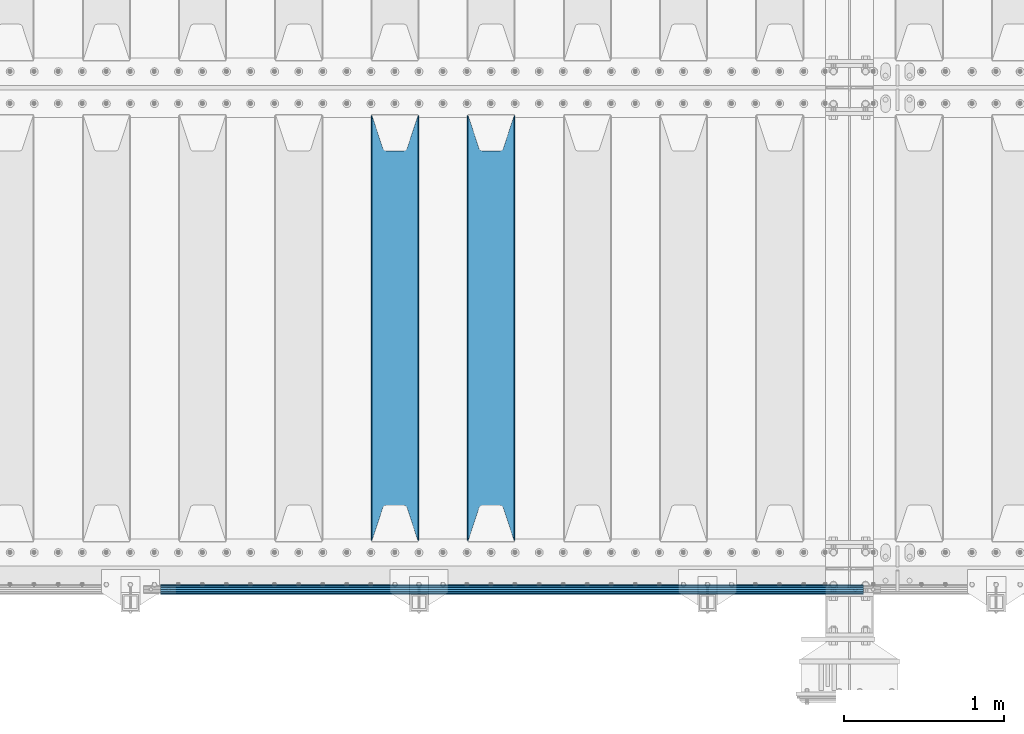
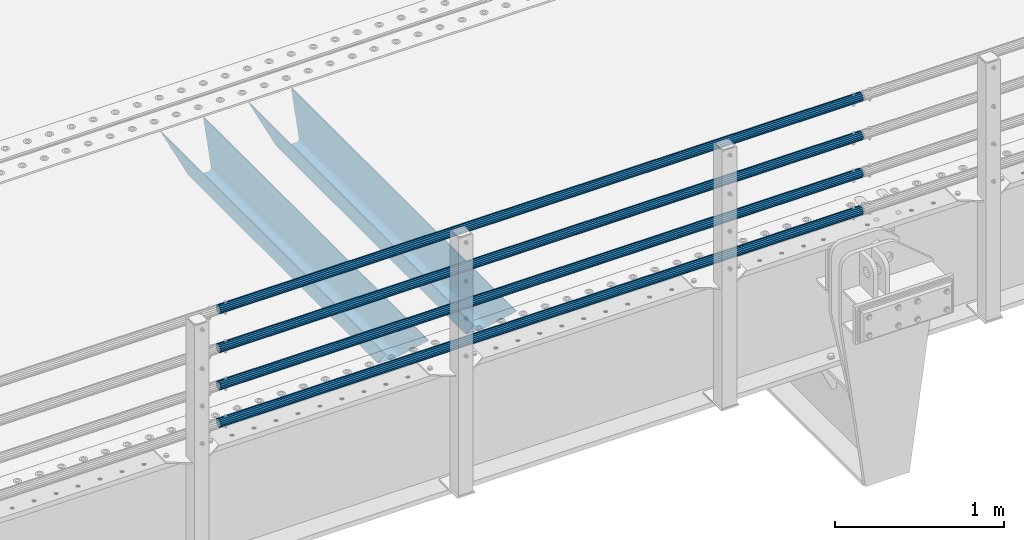
# One storey, part 120 of 242: 6 beams.
"""IFC2X3 building model written with IfcOpenShell, lengths in millimetres."""

from ifc_helpers import new_model, si_unit, frame, origin_with_axes, place, context, subcontext, project, spatial, faceted_brep, material, type_object, element, save


model = new_model("IFC2X3")

# Units and contexts
model_context = context("Model", 3, precision=1e-05, world=origin_with_axes())
body_context = subcontext(model_context, "Body", "Model", "MODEL_VIEW")
ifc_project = project(units=[si_unit("LENGTHUNIT", "METRE", prefix="MILLI"), si_unit("AREAUNIT", "SQUARE_METRE"), si_unit("VOLUMEUNIT", "CUBIC_METRE"), si_unit("MASSUNIT", "GRAM", prefix="KILO"), si_unit("TIMEUNIT", "SECOND"), si_unit("PLANEANGLEUNIT", "RADIAN"), si_unit("SOLIDANGLEUNIT", "STERADIAN"), si_unit("THERMODYNAMICTEMPERATUREUNIT", "DEGREE_CELSIUS"), si_unit("LUMINOUSINTENSITYUNIT", "LUMEN")], contexts=[model_context])

# Site, building, storey
site_placement = place(None, origin_with_axes())
site = spatial("IfcSite", under=ifc_project, at=site_placement, CompositionType="ELEMENT")
building_placement = place(site_placement, origin_with_axes())
building = spatial("IfcBuilding", under=site, at=building_placement, Name="Standard", CompositionType="ELEMENT")
storey_placement = place(building_placement, origin_with_axes())
storey = spatial("IfcBuildingStorey", under=building, at=storey_placement, Name="Undefined", CompositionType="ELEMENT", Elevation=0.0)

# Beams
ifc_material_1 = material()
beam_type_1 = type_object("IfcBeamType", PredefinedType="NOTDEFINED")
beam_1_placement = place(storey_placement, frame((-28328.0000000001, -24129.8499999998, 149.849999999726), z_axis=(0.0, 0.0, -1.0), x_axis=(-1.0, 0.0, 0.0)))
element("IfcBeam", 1, at=beam_1_placement, inside=storey, type_object=beam_type_1, material=ifc_material_1, context=body_context, shape_type="Brep", body=[
    faceted_brep([(0.0, -26.5499999999993, 0.0), (0.0, -24.5290015881765, 10.1602451292931), (4384.0, -24.5290015881765, 10.1602451292931), (4384.0, -26.5499999999993, 0.0), (0.0, -18.7736850405017, 18.7736850405028), (4384.0, -18.7736850405017, 18.7736850405028), (0.0, -10.1602451292929, 24.5290015881747), (4384.0, -10.1602451292929, 24.5290015881747), (0.0, 0.0, 26.55), (4384.0, 0.0, 26.55), (0.0, 10.1602451292929, 24.5290015881747), (4384.0, 10.1602451292929, 24.5290015881747), (0.0, 18.7736850405017, 18.7736850405028), (4384.0, 18.7736850405017, 18.7736850405028), (0.0, 24.5290015881765, 10.1602451292931), (4384.0, 24.5290015881765, 10.1602451292931), (0.0, 26.5499999999993, 0.0), (4384.0, 26.5499999999993, 0.0), (0.0, 24.5290015881765, -10.1602451292931), (4384.0, 24.5290015881765, -10.1602451292931), (0.0, 18.7736850405017, -18.7736850405028), (4384.0, 18.7736850405017, -18.7736850405028), (0.0, 10.1602451292929, -24.5290015881747), (4384.0, 10.1602451292929, -24.5290015881747), (0.0, 0.0, -26.55), (4384.0, 0.0, -26.55), (0.0, -10.1602451292929, -24.5290015881747), (4384.0, -10.1602451292929, -24.5290015881747), (0.0, -18.7736850405017, -18.7736850405028), (4384.0, -18.7736850405017, -18.7736850405028), (0.0, -24.5290015881765, -10.1602451292931), (4384.0, -24.5290015881765, -10.1602451292931), (0.0, -30.1500000000015, 0.0), (0.0, -27.8549679052157, -11.5379054858058), (4384.0, -27.8549679052157, -11.5379054858075), (4384.0, -30.1500000000015, 0.0), (0.0, -21.3192694527752, -21.3192694527752), (4384.0, -21.3192694527752, -21.3192694527744), (0.0, -11.5379054858058, -27.8549679052157), (4384.0, -11.5379054858058, -27.8549679052153), (0.0, 0.0, -30.1500000000015), (4384.0, 0.0, -30.15), (0.0, 11.5379054858058, -27.8549679052157), (4384.0, 11.5379054858058, -27.8549679052153), (0.0, 21.3192694527752, -21.3192694527752), (4384.0, 21.3192694527752, -21.3192694527744), (0.0, 27.8549679052157, -11.5379054858058), (4384.0, 27.8549679052157, -11.5379054858074), (0.0, 30.1500000000015, 0.0), (4384.0, 30.1500000000015, 0.0), (0.0, 27.8549679052157, 11.5379054858058), (4384.0, 27.8549679052157, 11.5379054858075), (0.0, 21.3192694527752, 21.3192694527752), (4384.0, 21.3192694527752, 21.3192694527744), (0.0, 11.5379054858058, 27.8549679052157), (4384.0, 11.5379054858058, 27.8549679052153), (0.0, 0.0, 30.1500000000015), (4384.0, 0.0, 30.15), (0.0, -11.5379054858058, 27.8549679052157), (4384.0, -11.5379054858058, 27.8549679052153), (0.0, -21.3192694527752, 21.3192694527752), (4384.0, -21.3192694527752, 21.3192694527744), (0.0, -27.8549679052157, 11.5379054858058), (4384.0, -27.8549679052157, 11.5379054858075)], [[[0, 1, 2, 3]], [[1, 4, 5, 2]], [[4, 6, 7, 5]], [[6, 8, 9, 7]], [[8, 10, 11, 9]], [[10, 12, 13, 11]], [[12, 14, 15, 13]], [[14, 16, 17, 15]], [[16, 18, 19, 17]], [[18, 20, 21, 19]], [[20, 22, 23, 21]], [[22, 24, 25, 23]], [[24, 26, 27, 25]], [[26, 28, 29, 27]], [[28, 30, 31, 29]], [[30, 0, 3, 31]], [[32, 33, 34, 35]], [[33, 36, 37, 34]], [[36, 38, 39, 37]], [[38, 40, 41, 39]], [[40, 42, 43, 41]], [[42, 44, 45, 43]], [[44, 46, 47, 45]], [[46, 48, 49, 47]], [[48, 50, 51, 49]], [[50, 52, 53, 51]], [[52, 54, 55, 53]], [[54, 56, 57, 55]], [[56, 58, 59, 57]], [[58, 60, 61, 59]], [[60, 62, 63, 61]], [[62, 32, 35, 63]], [[37, 39, 41, 43, 45, 47, 49, 51, 53, 55, 57, 59, 61, 63, 35, 34], [5, 7, 9, 11, 13, 15, 17, 19, 21, 23, 25, 27, 29, 31, 3, 2]], [[62, 60, 58, 56, 54, 52, 50, 48, 46, 44, 42, 40, 38, 36, 33, 32], [30, 28, 26, 24, 22, 20, 18, 16, 14, 12, 10, 8, 6, 4, 1, 0]]]),
])
beam_2_placement = place(storey_placement, frame((-28328.0000000001, -24129.8499999998, 420.149999999729), z_axis=(0.0, 0.0, -1.0), x_axis=(-1.0, 0.0, 0.0)))
element("IfcBeam", 2, at=beam_2_placement, inside=storey, type_object=beam_type_1, material=ifc_material_1, context=body_context, shape_type="Brep", body=[
    faceted_brep([(0.0, -26.5499999999993, 0.0), (0.0, -24.5290015881765, 10.1602451292931), (4384.0, -24.5290015881765, 10.1602451292931), (4384.0, -26.5499999999993, 0.0), (0.0, -18.7736850405017, 18.7736850405028), (4384.0, -18.7736850405017, 18.7736850405028), (0.0, -10.1602451292929, 24.5290015881747), (4384.0, -10.1602451292929, 24.5290015881747), (0.0, 0.0, 26.55), (4384.0, 0.0, 26.55), (0.0, 10.1602451292929, 24.5290015881747), (4384.0, 10.1602451292929, 24.5290015881747), (0.0, 18.7736850405017, 18.7736850405028), (4384.0, 18.7736850405017, 18.7736850405028), (0.0, 24.5290015881765, 10.1602451292931), (4384.0, 24.5290015881765, 10.1602451292931), (0.0, 26.5499999999993, 0.0), (4384.0, 26.5499999999993, 0.0), (0.0, 24.5290015881765, -10.1602451292931), (4384.0, 24.5290015881765, -10.1602451292931), (0.0, 18.7736850405017, -18.7736850405028), (4384.0, 18.7736850405017, -18.7736850405028), (0.0, 10.1602451292929, -24.5290015881747), (4384.0, 10.1602451292929, -24.5290015881747), (0.0, 0.0, -26.55), (4384.0, 0.0, -26.55), (0.0, -10.1602451292929, -24.5290015881747), (4384.0, -10.1602451292929, -24.5290015881747), (0.0, -18.7736850405017, -18.7736850405028), (4384.0, -18.7736850405017, -18.7736850405028), (0.0, -24.5290015881765, -10.1602451292931), (4384.0, -24.5290015881765, -10.1602451292931), (0.0, -30.1500000000015, 0.0), (0.0, -27.8549679052157, -11.5379054858058), (4384.0, -27.8549679052157, -11.5379054858075), (4384.0, -30.1500000000015, 0.0), (0.0, -21.3192694527752, -21.3192694527752), (4384.0, -21.3192694527752, -21.3192694527744), (0.0, -11.5379054858058, -27.8549679052157), (4384.0, -11.5379054858058, -27.8549679052153), (0.0, 0.0, -30.1500000000015), (4384.0, 0.0, -30.15), (0.0, 11.5379054858058, -27.8549679052157), (4384.0, 11.5379054858058, -27.8549679052153), (0.0, 21.3192694527752, -21.3192694527752), (4384.0, 21.3192694527752, -21.3192694527744), (0.0, 27.8549679052157, -11.5379054858058), (4384.0, 27.8549679052157, -11.5379054858074), (0.0, 30.1500000000015, 0.0), (4384.0, 30.1500000000015, 0.0), (0.0, 27.8549679052157, 11.5379054858058), (4384.0, 27.8549679052157, 11.5379054858075), (0.0, 21.3192694527752, 21.3192694527752), (4384.0, 21.3192694527752, 21.3192694527744), (0.0, 11.5379054858058, 27.8549679052157), (4384.0, 11.5379054858058, 27.8549679052153), (0.0, 0.0, 30.1500000000015), (4384.0, 0.0, 30.15), (0.0, -11.5379054858058, 27.8549679052157), (4384.0, -11.5379054858058, 27.8549679052153), (0.0, -21.3192694527752, 21.3192694527752), (4384.0, -21.3192694527752, 21.3192694527744), (0.0, -27.8549679052157, 11.5379054858058), (4384.0, -27.8549679052157, 11.5379054858075)], [[[0, 1, 2, 3]], [[1, 4, 5, 2]], [[4, 6, 7, 5]], [[6, 8, 9, 7]], [[8, 10, 11, 9]], [[10, 12, 13, 11]], [[12, 14, 15, 13]], [[14, 16, 17, 15]], [[16, 18, 19, 17]], [[18, 20, 21, 19]], [[20, 22, 23, 21]], [[22, 24, 25, 23]], [[24, 26, 27, 25]], [[26, 28, 29, 27]], [[28, 30, 31, 29]], [[30, 0, 3, 31]], [[32, 33, 34, 35]], [[33, 36, 37, 34]], [[36, 38, 39, 37]], [[38, 40, 41, 39]], [[40, 42, 43, 41]], [[42, 44, 45, 43]], [[44, 46, 47, 45]], [[46, 48, 49, 47]], [[48, 50, 51, 49]], [[50, 52, 53, 51]], [[52, 54, 55, 53]], [[54, 56, 57, 55]], [[56, 58, 59, 57]], [[58, 60, 61, 59]], [[60, 62, 63, 61]], [[62, 32, 35, 63]], [[37, 39, 41, 43, 45, 47, 49, 51, 53, 55, 57, 59, 61, 63, 35, 34], [5, 7, 9, 11, 13, 15, 17, 19, 21, 23, 25, 27, 29, 31, 3, 2]], [[62, 60, 58, 56, 54, 52, 50, 48, 46, 44, 42, 40, 38, 36, 33, 32], [30, 28, 26, 24, 22, 20, 18, 16, 14, 12, 10, 8, 6, 4, 1, 0]]]),
])
beam_3_placement = place(storey_placement, frame((-28328.0000000001, -24129.8499999998, 969.849999999726), z_axis=(0.0, 0.0, -1.0), x_axis=(-1.0, 0.0, 0.0)))
element("IfcBeam", 3, at=beam_3_placement, inside=storey, type_object=beam_type_1, material=ifc_material_1, context=body_context, shape_type="Brep", body=[
    faceted_brep([(0.0, -26.5499999999993, 0.0), (0.0, -24.5290015881765, 10.1602451292931), (4384.0, -24.5290015881765, 10.1602451292931), (4384.0, -26.5499999999993, 0.0), (0.0, -18.7736850405017, 18.7736850405028), (4384.0, -18.7736850405017, 18.7736850405028), (0.0, -10.1602451292929, 24.5290015881747), (4384.0, -10.1602451292929, 24.5290015881747), (0.0, 0.0, 26.55), (4384.0, 0.0, 26.55), (0.0, 10.1602451292929, 24.5290015881747), (4384.0, 10.1602451292929, 24.5290015881747), (0.0, 18.7736850405017, 18.7736850405028), (4384.0, 18.7736850405017, 18.7736850405028), (0.0, 24.5290015881765, 10.1602451292931), (4384.0, 24.5290015881765, 10.1602451292931), (0.0, 26.5499999999993, 0.0), (4384.0, 26.5499999999993, 0.0), (0.0, 24.5290015881765, -10.1602451292931), (4384.0, 24.5290015881765, -10.1602451292931), (0.0, 18.7736850405017, -18.7736850405028), (4384.0, 18.7736850405017, -18.7736850405028), (0.0, 10.1602451292929, -24.5290015881747), (4384.0, 10.1602451292929, -24.5290015881747), (0.0, 0.0, -26.55), (4384.0, 0.0, -26.55), (0.0, -10.1602451292929, -24.5290015881747), (4384.0, -10.1602451292929, -24.5290015881747), (0.0, -18.7736850405017, -18.7736850405028), (4384.0, -18.7736850405017, -18.7736850405028), (0.0, -24.5290015881765, -10.1602451292931), (4384.0, -24.5290015881765, -10.1602451292931), (0.0, -30.1500000000015, 0.0), (0.0, -27.8549679052157, -11.5379054858058), (4384.0, -27.8549679052157, -11.5379054858075), (4384.0, -30.1500000000015, 0.0), (0.0, -21.3192694527752, -21.3192694527752), (4384.0, -21.3192694527752, -21.3192694527744), (0.0, -11.5379054858058, -27.8549679052157), (4384.0, -11.5379054858058, -27.8549679052153), (0.0, 0.0, -30.1500000000015), (4384.0, 0.0, -30.15), (0.0, 11.5379054858058, -27.8549679052157), (4384.0, 11.5379054858058, -27.8549679052153), (0.0, 21.3192694527752, -21.3192694527752), (4384.0, 21.3192694527752, -21.3192694527744), (0.0, 27.8549679052157, -11.5379054858058), (4384.0, 27.8549679052157, -11.5379054858074), (0.0, 30.1500000000015, 0.0), (4384.0, 30.1500000000015, 0.0), (0.0, 27.8549679052157, 11.5379054858058), (4384.0, 27.8549679052157, 11.5379054858075), (0.0, 21.3192694527752, 21.3192694527752), (4384.0, 21.3192694527752, 21.3192694527744), (0.0, 11.5379054858058, 27.8549679052157), (4384.0, 11.5379054858058, 27.8549679052153), (0.0, 0.0, 30.1500000000015), (4384.0, 0.0, 30.15), (0.0, -11.5379054858058, 27.8549679052157), (4384.0, -11.5379054858058, 27.8549679052153), (0.0, -21.3192694527752, 21.3192694527752), (4384.0, -21.3192694527752, 21.3192694527744), (0.0, -27.8549679052157, 11.5379054858058), (4384.0, -27.8549679052157, 11.5379054858075)], [[[0, 1, 2, 3]], [[1, 4, 5, 2]], [[4, 6, 7, 5]], [[6, 8, 9, 7]], [[8, 10, 11, 9]], [[10, 12, 13, 11]], [[12, 14, 15, 13]], [[14, 16, 17, 15]], [[16, 18, 19, 17]], [[18, 20, 21, 19]], [[20, 22, 23, 21]], [[22, 24, 25, 23]], [[24, 26, 27, 25]], [[26, 28, 29, 27]], [[28, 30, 31, 29]], [[30, 0, 3, 31]], [[32, 33, 34, 35]], [[33, 36, 37, 34]], [[36, 38, 39, 37]], [[38, 40, 41, 39]], [[40, 42, 43, 41]], [[42, 44, 45, 43]], [[44, 46, 47, 45]], [[46, 48, 49, 47]], [[48, 50, 51, 49]], [[50, 52, 53, 51]], [[52, 54, 55, 53]], [[54, 56, 57, 55]], [[56, 58, 59, 57]], [[58, 60, 61, 59]], [[60, 62, 63, 61]], [[62, 32, 35, 63]], [[37, 39, 41, 43, 45, 47, 49, 51, 53, 55, 57, 59, 61, 63, 35, 34], [5, 7, 9, 11, 13, 15, 17, 19, 21, 23, 25, 27, 29, 31, 3, 2]], [[62, 60, 58, 56, 54, 52, 50, 48, 46, 44, 42, 40, 38, 36, 33, 32], [30, 28, 26, 24, 22, 20, 18, 16, 14, 12, 10, 8, 6, 4, 1, 0]]]),
])
beam_4_placement = place(storey_placement, frame((-28328.0000000001, -24129.8499999998, 689.849999999726), z_axis=(0.0, 0.0, -1.0), x_axis=(-1.0, 0.0, 0.0)))
element("IfcBeam", 4, at=beam_4_placement, inside=storey, type_object=beam_type_1, material=ifc_material_1, context=body_context, shape_type="Brep", body=[
    faceted_brep([(0.0, -26.5499999999993, 0.0), (0.0, -24.5290015881765, 10.1602451292931), (4384.0, -24.5290015881765, 10.1602451292931), (4384.0, -26.5499999999993, 0.0), (0.0, -18.7736850405017, 18.7736850405028), (4384.0, -18.7736850405017, 18.7736850405028), (0.0, -10.1602451292929, 24.5290015881747), (4384.0, -10.1602451292929, 24.5290015881747), (0.0, 0.0, 26.55), (4384.0, 0.0, 26.55), (0.0, 10.1602451292929, 24.5290015881747), (4384.0, 10.1602451292929, 24.5290015881747), (0.0, 18.7736850405017, 18.7736850405028), (4384.0, 18.7736850405017, 18.7736850405028), (0.0, 24.5290015881765, 10.1602451292931), (4384.0, 24.5290015881765, 10.1602451292931), (0.0, 26.5499999999993, 0.0), (4384.0, 26.5499999999993, 0.0), (0.0, 24.5290015881765, -10.1602451292931), (4384.0, 24.5290015881765, -10.1602451292931), (0.0, 18.7736850405017, -18.7736850405028), (4384.0, 18.7736850405017, -18.7736850405028), (0.0, 10.1602451292929, -24.5290015881747), (4384.0, 10.1602451292929, -24.5290015881747), (0.0, 0.0, -26.55), (4384.0, 0.0, -26.55), (0.0, -10.1602451292929, -24.5290015881747), (4384.0, -10.1602451292929, -24.5290015881747), (0.0, -18.7736850405017, -18.7736850405028), (4384.0, -18.7736850405017, -18.7736850405028), (0.0, -24.5290015881765, -10.1602451292931), (4384.0, -24.5290015881765, -10.1602451292931), (0.0, -30.1500000000015, 0.0), (0.0, -27.8549679052157, -11.5379054858058), (4384.0, -27.8549679052157, -11.5379054858075), (4384.0, -30.1500000000015, 0.0), (0.0, -21.3192694527752, -21.3192694527752), (4384.0, -21.3192694527752, -21.3192694527744), (0.0, -11.5379054858058, -27.8549679052157), (4384.0, -11.5379054858058, -27.8549679052153), (0.0, 0.0, -30.1500000000015), (4384.0, 0.0, -30.15), (0.0, 11.5379054858058, -27.8549679052157), (4384.0, 11.5379054858058, -27.8549679052153), (0.0, 21.3192694527752, -21.3192694527752), (4384.0, 21.3192694527752, -21.3192694527744), (0.0, 27.8549679052157, -11.5379054858058), (4384.0, 27.8549679052157, -11.5379054858074), (0.0, 30.1500000000015, 0.0), (4384.0, 30.1500000000015, 0.0), (0.0, 27.8549679052157, 11.5379054858058), (4384.0, 27.8549679052157, 11.5379054858075), (0.0, 21.3192694527752, 21.3192694527752), (4384.0, 21.3192694527752, 21.3192694527744), (0.0, 11.5379054858058, 27.8549679052157), (4384.0, 11.5379054858058, 27.8549679052153), (0.0, 0.0, 30.1500000000015), (4384.0, 0.0, 30.15), (0.0, -11.5379054858058, 27.8549679052157), (4384.0, -11.5379054858058, 27.8549679052153), (0.0, -21.3192694527752, 21.3192694527752), (4384.0, -21.3192694527752, 21.3192694527744), (0.0, -27.8549679052157, 11.5379054858058), (4384.0, -27.8549679052157, 11.5379054858075)], [[[0, 1, 2, 3]], [[1, 4, 5, 2]], [[4, 6, 7, 5]], [[6, 8, 9, 7]], [[8, 10, 11, 9]], [[10, 12, 13, 11]], [[12, 14, 15, 13]], [[14, 16, 17, 15]], [[16, 18, 19, 17]], [[18, 20, 21, 19]], [[20, 22, 23, 21]], [[22, 24, 25, 23]], [[24, 26, 27, 25]], [[26, 28, 29, 27]], [[28, 30, 31, 29]], [[30, 0, 3, 31]], [[32, 33, 34, 35]], [[33, 36, 37, 34]], [[36, 38, 39, 37]], [[38, 40, 41, 39]], [[40, 42, 43, 41]], [[42, 44, 45, 43]], [[44, 46, 47, 45]], [[46, 48, 49, 47]], [[48, 50, 51, 49]], [[50, 52, 53, 51]], [[52, 54, 55, 53]], [[54, 56, 57, 55]], [[56, 58, 59, 57]], [[58, 60, 61, 59]], [[60, 62, 63, 61]], [[62, 32, 35, 63]], [[37, 39, 41, 43, 45, 47, 49, 51, 53, 55, 57, 59, 61, 63, 35, 34], [5, 7, 9, 11, 13, 15, 17, 19, 21, 23, 25, 27, 29, 31, 3, 2]], [[62, 60, 58, 56, 54, 52, 50, 48, 46, 44, 42, 40, 38, 36, 33, 32], [30, 28, 26, 24, 22, 20, 18, 16, 14, 12, 10, 8, 6, 4, 1, 0]]]),
])
ifc_material_2 = material(Name="STEEL/S355N")
beam_type_2 = type_object("IfcBeamType", PredefinedType="NOTDEFINED")
beam_5_placement = place(storey_placement, frame((-30650.0, -23825.0, -115.0), z_axis=(0.0, 0.0, 1.0), x_axis=(0.0, 1.0, 0.0)))
element("IfcBeam", 5, at=beam_5_placement, inside=storey, type_object=beam_type_2, material=ifc_material_2, context=body_context, shape_type="Brep", body=[
    faceted_brep([(0.0, 150.0, 115.0), (0.0, 143.689999999999, 115.0), (2650.00000000297, 143.689999999999, 115.0), (2650.00000000297, 150.0, 115.0), (2650.00000000297, 142.059565218402, 110.000000003099), (2650.00000000297, 148.369565218403, 110.000000003099), (2441.90079219209, -80.1103600731112, -98.0992078077845), (2437.7588105432, -77.5672621345584, -102.241189456673), (2434.06523489747, -74.4080125315522, -105.934765102404), (2430.91086095089, -70.710272125576, -109.089139048974), (2428.37322971128, -66.5649389910068, -111.626770288588), (2426.51472138055, -62.0739139532889, -113.485278619323), (2425.38102192092, -57.3475956567672, -114.618978078955), (2424.99999999987, -52.5021667386536, -115.0), (2424.99999999987, 52.5021667386536, -115.0), (2425.38102192092, 57.3475956567672, -114.618978078955), (2426.51472138055, 62.0739139532889, -113.485278619323), (2428.37322971128, 66.5649389910068, -111.626770288588), (2430.91086095089, 70.710272125576, -109.089139048974), (2434.06523489747, 74.4080125315522, -105.934765102404), (2437.7588105432, 77.5672621345584, -102.241189456673), (2441.90079219209, 80.1103600731112, -98.0992078077846), (2446.38936140511, 81.9747917625791, -93.6106385947584), (2448.2494850041, 76.2713538057251, -91.7505149957729), (2444.62967112262, 74.76777986261, -95.3703288772456), (2441.28936334126, 72.7168944282894, -98.710636658607), (2438.31067330438, 70.1691124903846, -101.689326695487), (2435.76682334747, 67.1870637758839, -104.233176652398), (2433.72034654133, 63.8440531834895, -106.279653458539), (2432.22154950042, 60.222258798236, -107.778450499454), (2431.30727574265, 56.4107117849089, -108.692724257221), (2430.99999999987, 52.5031078186876, -109.0), (2430.99999999987, -52.5031078186876, -109.0), (2431.30727574265, -56.4107117849089, -108.692724257221), (2432.22154950042, -60.222258798236, -107.778450499454), (2433.72034654133, -63.8440531834895, -106.279653458539), (2435.76682334747, -67.1870637758839, -104.233176652398), (2438.31067330438, -70.1691124903846, -101.689326695487), (2441.28936334126, -72.7168944282894, -98.7106366586071), (2444.62967112262, -74.76777986261, -95.3703288772457), (2448.2494850041, -76.2713538057251, -91.7505149957729), (2650.00000000297, -142.059565218402, 110.000000003099), (2650.00000000297, -148.369565218403, 110.000000003099), (2446.38936140511, -81.9747917625791, -93.6106385947584), (2650.00000000297, -143.689999999999, 115.0), (2650.00000000297, -150.0, 115.0), (0.0, -143.689999999999, 115.0), (0.0, -150.0, 115.0), (0.0, -148.369565218261, 110.000000002669), (203.610638597427, -81.9747917625791, -93.6106385947584), (208.099207810454, -80.1103600731112, -98.0992078077845), (212.241189459342, -77.5672621345584, -102.241189456673), (215.934765105074, -74.4080125315522, -105.934765102404), (219.089139051644, -70.710272125576, -109.089139048974), (221.626770291256, -66.5649389910068, -111.626770288588), (223.485278621993, -62.0739139532889, -113.485278619323), (224.618978081624, -57.3475956567672, -114.618978078955), (225.00000000267, -52.5021667386536, -115.0), (225.00000000267, 52.5021667386536, -115.0), (224.618978081624, 57.3475956567672, -114.618978078955), (223.485278621993, 62.0739139532889, -113.485278619323), (221.626770291256, 66.5649389910068, -111.626770288588), (219.089139051644, 70.710272125576, -109.089139048974), (215.934765105074, 74.4080125315522, -105.934765102404), (212.241189459342, 77.5672621345584, -102.241189456673), (208.099207810454, 80.1103600731112, -98.0992078077846), (203.610638597427, 81.9747917625791, -93.6106385947584), (0.0, 148.369565218261, 110.000000002669), (0.0, 142.05956521826, 110.000000002669), (201.750514998443, 76.2713538057251, -91.7505149957729), (205.370328879915, 74.76777986261, -95.3703288772456), (208.710636661275, 72.7168944282894, -98.710636658607), (211.689326698157, 70.1691124903846, -101.689326695487), (214.233176655067, 67.1870637758839, -104.233176652398), (216.279653461206, 63.8440531834895, -106.279653458539), (217.778450502123, 60.222258798236, -107.778450499454), (218.69272425989, 56.4107117849089, -108.692724257221), (219.00000000267, 52.5031078186876, -109.0), (219.00000000267, -52.5031078186876, -109.0), (218.69272425989, -56.4107117849089, -108.692724257221), (217.778450502123, -60.222258798236, -107.778450499454), (216.279653461206, -63.8440531834895, -106.279653458539), (214.233176655067, -67.1870637758839, -104.233176652398), (211.689326698157, -70.1691124903846, -101.689326695487), (208.710636661275, -72.7168944282894, -98.7106366586071), (205.370328879915, -74.76777986261, -95.3703288772457), (201.750514998443, -76.2713538057251, -91.7505149957729), (0.0, -142.05956521826, 110.000000002669)], [[[0, 1, 2, 3]], [[3, 2, 4, 5]], [[6, 7, 8, 9, 10, 11, 12, 13, 14, 15, 16, 17, 18, 19, 20, 21, 22, 5, 4, 23, 24, 25, 26, 27, 28, 29, 30, 31, 32, 33, 34, 35, 36, 37, 38, 39, 40, 41, 42, 43]], [[44, 45, 42, 41]], [[46, 47, 45, 44]], [[43, 42, 45, 47, 48, 49]], [[6, 43, 49, 50]], [[7, 6, 50, 51]], [[8, 7, 51, 52]], [[9, 8, 52, 53]], [[10, 9, 53, 54]], [[11, 10, 54, 55]], [[12, 11, 55, 56]], [[13, 12, 56, 57]], [[14, 13, 57, 58]], [[15, 14, 58, 59]], [[16, 15, 59, 60]], [[17, 16, 60, 61]], [[18, 17, 61, 62]], [[19, 18, 62, 63]], [[20, 19, 63, 64]], [[21, 20, 64, 65]], [[22, 21, 65, 66]], [[0, 3, 5, 22, 66, 67]], [[1, 0, 67, 68]], [[23, 4, 2, 1, 68, 69]], [[24, 23, 69, 70]], [[25, 24, 70, 71]], [[26, 25, 71, 72]], [[27, 26, 72, 73]], [[28, 27, 73, 74]], [[29, 28, 74, 75]], [[30, 29, 75, 76]], [[31, 30, 76, 77]], [[32, 31, 77, 78]], [[33, 32, 78, 79]], [[34, 33, 79, 80]], [[35, 34, 80, 81]], [[36, 35, 81, 82]], [[37, 36, 82, 83]], [[38, 37, 83, 84]], [[39, 38, 84, 85]], [[40, 39, 85, 86]], [[46, 44, 41, 40, 86, 87]], [[47, 46, 87, 48]], [[86, 85, 84, 83, 82, 81, 80, 79, 78, 77, 76, 75, 74, 73, 72, 71, 70, 69, 68, 67, 66, 65, 64, 63, 62, 61, 60, 59, 58, 57, 56, 55, 54, 53, 52, 51, 50, 49, 48, 87]]]),
])
beam_6_placement = place(storey_placement, frame((-31250.0, -23825.0, -115.0), z_axis=(0.0, 0.0, 1.0), x_axis=(0.0, 1.0, 0.0)))
element("IfcBeam", 6, at=beam_6_placement, inside=storey, type_object=beam_type_2, material=ifc_material_2, context=body_context, shape_type="Brep", body=[
    faceted_brep([(0.0, 150.0, 115.0), (0.0, 143.689999999999, 115.0), (2650.00000000297, 143.689999999999, 115.0), (2650.00000000297, 150.0, 115.0), (2650.00000000297, 142.059565218402, 110.000000003099), (2650.00000000297, 148.369565218403, 110.000000003099), (2441.90079219209, -80.1103600731112, -98.0992078077845), (2437.7588105432, -77.5672621345584, -102.241189456673), (2434.06523489747, -74.4080125315522, -105.934765102404), (2430.91086095089, -70.710272125576, -109.089139048974), (2428.37322971128, -66.5649389910068, -111.626770288588), (2426.51472138055, -62.0739139532889, -113.485278619323), (2425.38102192092, -57.3475956567672, -114.618978078955), (2424.99999999987, -52.5021667386536, -115.0), (2424.99999999987, 52.5021667386536, -115.0), (2425.38102192092, 57.3475956567672, -114.618978078955), (2426.51472138055, 62.0739139532889, -113.485278619323), (2428.37322971128, 66.5649389910068, -111.626770288588), (2430.91086095089, 70.710272125576, -109.089139048974), (2434.06523489747, 74.4080125315522, -105.934765102404), (2437.7588105432, 77.5672621345584, -102.241189456673), (2441.90079219209, 80.1103600731112, -98.0992078077846), (2446.38936140511, 81.9747917625791, -93.6106385947584), (2448.2494850041, 76.2713538057251, -91.7505149957729), (2444.62967112262, 74.76777986261, -95.3703288772456), (2441.28936334126, 72.7168944282894, -98.710636658607), (2438.31067330438, 70.1691124903846, -101.689326695487), (2435.76682334747, 67.1870637758839, -104.233176652398), (2433.72034654133, 63.8440531834895, -106.279653458539), (2432.22154950042, 60.222258798236, -107.778450499454), (2431.30727574265, 56.4107117849089, -108.692724257221), (2430.99999999987, 52.5031078186876, -109.0), (2430.99999999987, -52.5031078186876, -109.0), (2431.30727574265, -56.4107117849089, -108.692724257221), (2432.22154950042, -60.222258798236, -107.778450499454), (2433.72034654133, -63.8440531834895, -106.279653458539), (2435.76682334747, -67.1870637758839, -104.233176652398), (2438.31067330438, -70.1691124903846, -101.689326695487), (2441.28936334126, -72.7168944282894, -98.7106366586071), (2444.62967112262, -74.76777986261, -95.3703288772457), (2448.2494850041, -76.2713538057251, -91.7505149957729), (2650.00000000297, -142.059565218402, 110.000000003099), (2650.00000000297, -148.369565218403, 110.000000003099), (2446.38936140511, -81.9747917625791, -93.6106385947584), (2650.00000000297, -143.689999999999, 115.0), (2650.00000000297, -150.0, 115.0), (0.0, -143.689999999999, 115.0), (0.0, -150.0, 115.0), (0.0, -148.369565218261, 110.000000002669), (203.610638597427, -81.9747917625791, -93.6106385947584), (208.099207810454, -80.1103600731112, -98.0992078077845), (212.241189459342, -77.5672621345584, -102.241189456673), (215.934765105074, -74.4080125315522, -105.934765102404), (219.089139051644, -70.710272125576, -109.089139048974), (221.626770291256, -66.5649389910068, -111.626770288588), (223.485278621993, -62.0739139532889, -113.485278619323), (224.618978081624, -57.3475956567672, -114.618978078955), (225.00000000267, -52.5021667386536, -115.0), (225.00000000267, 52.5021667386536, -115.0), (224.618978081624, 57.3475956567672, -114.618978078955), (223.485278621993, 62.0739139532889, -113.485278619323), (221.626770291256, 66.5649389910068, -111.626770288588), (219.089139051644, 70.710272125576, -109.089139048974), (215.934765105074, 74.4080125315522, -105.934765102404), (212.241189459342, 77.5672621345584, -102.241189456673), (208.099207810454, 80.1103600731112, -98.0992078077846), (203.610638597427, 81.9747917625791, -93.6106385947584), (0.0, 148.369565218261, 110.000000002669), (0.0, 142.05956521826, 110.000000002669), (201.750514998443, 76.2713538057251, -91.7505149957729), (205.370328879915, 74.76777986261, -95.3703288772456), (208.710636661275, 72.7168944282894, -98.710636658607), (211.689326698157, 70.1691124903846, -101.689326695487), (214.233176655067, 67.1870637758839, -104.233176652398), (216.279653461206, 63.8440531834895, -106.279653458539), (217.778450502123, 60.222258798236, -107.778450499454), (218.69272425989, 56.4107117849089, -108.692724257221), (219.00000000267, 52.5031078186876, -109.0), (219.00000000267, -52.5031078186876, -109.0), (218.69272425989, -56.4107117849089, -108.692724257221), (217.778450502123, -60.222258798236, -107.778450499454), (216.279653461206, -63.8440531834895, -106.279653458539), (214.233176655067, -67.1870637758839, -104.233176652398), (211.689326698157, -70.1691124903846, -101.689326695487), (208.710636661275, -72.7168944282894, -98.7106366586071), (205.370328879915, -74.76777986261, -95.3703288772457), (201.750514998443, -76.2713538057251, -91.7505149957729), (0.0, -142.05956521826, 110.000000002669)], [[[0, 1, 2, 3]], [[3, 2, 4, 5]], [[6, 7, 8, 9, 10, 11, 12, 13, 14, 15, 16, 17, 18, 19, 20, 21, 22, 5, 4, 23, 24, 25, 26, 27, 28, 29, 30, 31, 32, 33, 34, 35, 36, 37, 38, 39, 40, 41, 42, 43]], [[44, 45, 42, 41]], [[46, 47, 45, 44]], [[43, 42, 45, 47, 48, 49]], [[6, 43, 49, 50]], [[7, 6, 50, 51]], [[8, 7, 51, 52]], [[9, 8, 52, 53]], [[10, 9, 53, 54]], [[11, 10, 54, 55]], [[12, 11, 55, 56]], [[13, 12, 56, 57]], [[14, 13, 57, 58]], [[15, 14, 58, 59]], [[16, 15, 59, 60]], [[17, 16, 60, 61]], [[18, 17, 61, 62]], [[19, 18, 62, 63]], [[20, 19, 63, 64]], [[21, 20, 64, 65]], [[22, 21, 65, 66]], [[0, 3, 5, 22, 66, 67]], [[1, 0, 67, 68]], [[23, 4, 2, 1, 68, 69]], [[24, 23, 69, 70]], [[25, 24, 70, 71]], [[26, 25, 71, 72]], [[27, 26, 72, 73]], [[28, 27, 73, 74]], [[29, 28, 74, 75]], [[30, 29, 75, 76]], [[31, 30, 76, 77]], [[32, 31, 77, 78]], [[33, 32, 78, 79]], [[34, 33, 79, 80]], [[35, 34, 80, 81]], [[36, 35, 81, 82]], [[37, 36, 82, 83]], [[38, 37, 83, 84]], [[39, 38, 84, 85]], [[40, 39, 85, 86]], [[46, 44, 41, 40, 86, 87]], [[47, 46, 87, 48]], [[86, 85, 84, 83, 82, 81, 80, 79, 78, 77, 76, 75, 74, 73, 72, 71, 70, 69, 68, 67, 66, 65, 64, 63, 62, 61, 60, 59, 58, 57, 56, 55, 54, 53, 52, 51, 50, 49, 48, 87]]]),
])

save(model, "model.ifc")
